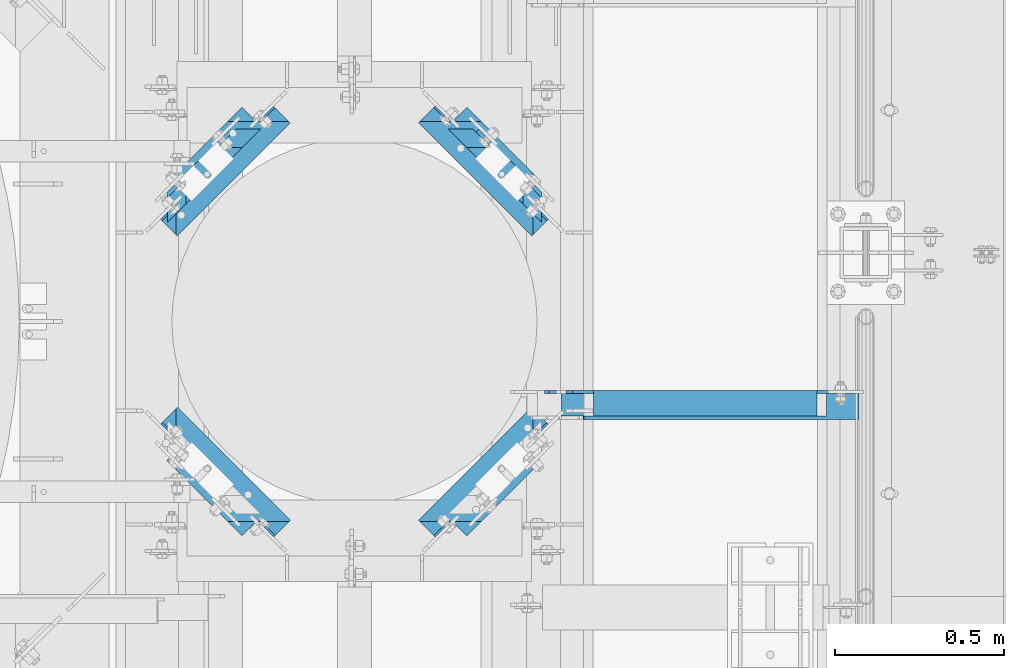
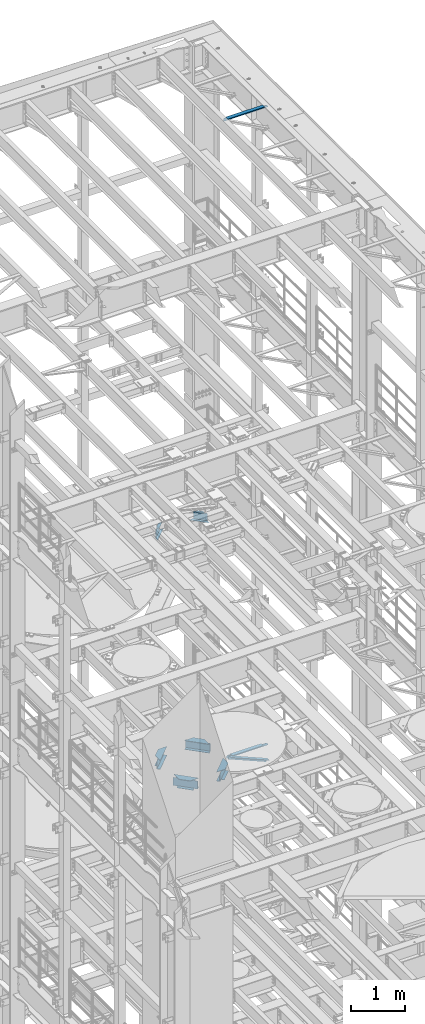
# One storey, part 1324 of 1876: 8 beams, 1 member, 9 elements without a shape of their own.
"""IFC2X3 building model written with IfcOpenShell, lengths in millimetres."""

import ifcopenshell
import ifcopenshell.guid

model = None  # the IFC model being written
_history = None  # IfcOwnerHistory: only IFC2X3 demands one
_inside = {}  # id of a spatial element -> (the spatial element, [elements in it])
_under = {}  # id of a project, library or spatial element -> (it, [spatial elements below it])
_declared = {}  # id of a project -> (the project, [libraries it declares])
_typed = {}  # id of a type object -> (the type object, [elements of that type])
_made_of = {}  # id of a material, layer set ... -> (it, [elements and type objects made of it])


def new_model(schema):
    """Start an empty IFC model of exactly this schema.

    Asked for "IFC4X3", IfcOpenShell would pick the latest addendum, in which some entities
    have other attributes; the version numbers below select the first issue.
    IFC2X3 requires an IfcOwnerHistory on every rooted entity: one is made here for all.
    """
    global model, _history
    if schema == "IFC4X3":
        model = ifcopenshell.file(schema_version=(4, 3, 0, 0))
    else:
        model = ifcopenshell.file(schema=schema)
    _inside.clear()
    _under.clear()
    _declared.clear()
    _typed.clear()
    _made_of.clear()
    _history = None
    if model.schema == "IFC2X3":
        org = make("IfcOrganization", Name="unknown")
        user = make(
            "IfcPersonAndOrganization",
            ThePerson=make("IfcPerson", FamilyName="unknown"),
            TheOrganization=org,
        )
        app = make(
            "IfcApplication",
            ApplicationDeveloper=org,
            Version="unknown",
            ApplicationFullName="unknown",
            ApplicationIdentifier="unknown",
        )
        _history = make(
            "IfcOwnerHistory",
            OwningUser=user,
            OwningApplication=app,
            ChangeAction="ADDED",
            CreationDate=0,
        )
    return model


def make(cls, **values):
    """One entity of the class cls with the attributes given. An attribute that is None is left unset."""
    return model.create_entity(
        cls, **{name: value for name, value in values.items() if value is not None}
    )


def rooted(cls, **values):
    """An entity with a GlobalId (a new one), such as an element, a storey or a relation."""
    return make(cls, GlobalId=ifcopenshell.guid.new(), OwnerHistory=_history, **values)


def si_unit(unit_type, name, prefix=None):
    """IfcSIUnit, for example si_unit("LENGTHUNIT", "METRE", prefix="MILLI")."""
    return make("IfcSIUnit", UnitType=unit_type, Prefix=prefix, Name=name)


def assignment(units):
    """IfcUnitAssignment: the units of a project."""
    return None if units is None else make("IfcUnitAssignment", Units=units)


def point(xyz):
    """IfcCartesianPoint."""
    return None if xyz is None else make("IfcCartesianPoint", Coordinates=xyz)


def direction(xyz):
    """IfcDirection."""
    return None if xyz is None else make("IfcDirection", DirectionRatios=xyz)


def frame(location, z_axis=None, x_axis=None):
    """IfcAxis2Placement3D, a coordinate frame: its origin and axes. An axis left out is left unset."""
    return make(
        "IfcAxis2Placement3D",
        Location=point(location),
        Axis=direction(z_axis),
        RefDirection=direction(x_axis),
    )


def origin_with_axes():
    """The frame at (0, 0, 0) with the z axis (0, 0, 1) and the x axis (1, 0, 0) written out."""
    return frame((0.0, 0.0, 0.0), z_axis=(0.0, 0.0, 1.0), x_axis=(1.0, 0.0, 0.0))


def place(relative_to, where):
    """IfcLocalPlacement: puts the frame where relative to a parent placement (None: the world)."""
    return make(
        "IfcLocalPlacement", PlacementRelTo=relative_to, RelativePlacement=where
    )


def context(
    kind, dimensions, precision=None, world=None, true_north=None, identifier=None
):
    """IfcGeometricRepresentationContext, for example the 3D "Model" context."""
    return make(
        "IfcGeometricRepresentationContext",
        ContextIdentifier=identifier,
        ContextType=kind,
        CoordinateSpaceDimension=dimensions,
        Precision=precision,
        WorldCoordinateSystem=world,
        TrueNorth=true_north,
    )


def subcontext(parent, identifier, kind, view, scale=None):
    """IfcGeometricRepresentationSubContext, for example "Body" below "Model"."""
    return make(
        "IfcGeometricRepresentationSubContext",
        ContextIdentifier=identifier,
        ContextType=kind,
        ParentContext=parent,
        TargetScale=scale,
        TargetView=view,
    )


def project(units=None, contexts=None):
    """IfcProject with its units and contexts."""
    return rooted(
        "IfcProject",
        Name="project",
        RepresentationContexts=contexts,
        UnitsInContext=assignment(units),
    )


def spatial(cls, under=None, at=None, **own):
    """A site, building, storey or space (cls), placed at a placement, below another one or the project."""
    s = rooted(cls, ObjectPlacement=at, **own)
    if under is not None:
        _under.setdefault(under.id(), (under, []))[1].append(s)
    return s


def faces_of(points, faces, orient=None, outer=None):
    """IfcFace entities. A face is a list of loops; a loop is a list of indices into points, from 0.

    orient and outer hold one flag for each loop. By default every Orientation is true, the
    first loop of a face is its IfcFaceOuterBound and the others are IfcFaceBound.
    """
    made = []
    for i, loops in enumerate(faces):
        bounds = []
        for j, loop in enumerate(loops):
            is_outer = j == 0 if outer is None else outer[i][j]
            bounds.append(
                make(
                    "IfcFaceOuterBound" if is_outer else "IfcFaceBound",
                    Bound=make("IfcPolyLoop", Polygon=[points[k] for k in loop]),
                    Orientation=True if orient is None else orient[i][j],
                )
            )
        made.append(make("IfcFace", Bounds=bounds))
    return made


def faceted_brep(points, faces, orient=None, outer=None, voids=None):
    """IfcFacetedBrep: a solid bounded by flat faces; with voids (closed shells), ...WithVoids."""
    shared = [point(p) for p in points]
    hull = make("IfcClosedShell", CfsFaces=faces_of(shared, faces, orient, outer))
    if voids is None:
        return make("IfcFacetedBrep", Outer=hull)
    return make(
        "IfcFacetedBrepWithVoids",
        Outer=hull,
        Voids=[
            make(cls, CfsFaces=faces_of(shared, fs, o, b)) for cls, fs, o, b in voids
        ],
    )


def shape(context_of_items, identifier, shape_type, items):
    """IfcShapeRepresentation: the items that make up one representation, for example the "Body"."""
    return make(
        "IfcShapeRepresentation",
        ContextOfItems=context_of_items,
        RepresentationIdentifier=identifier,
        RepresentationType=shape_type,
        Items=items,
    )


def material(Name=None, Category=None):
    """IfcMaterial."""
    return make("IfcMaterial", Name=Name, Category=Category)


def made_of(thing, what):
    """Note that an element or type object is made of a material, layer set ...; save() writes the relation."""
    if what is not None:
        _made_of.setdefault(what.id(), (what, []))[1].append(thing)
    return thing


def type_object(cls, material=None, **own):
    """A type object (cls), such as IfcWallType, which elements share."""
    return made_of(rooted(cls, **own), material)


def element(
    cls,
    number,
    at=None,
    inside=None,
    cuts=None,
    type_object=None,
    material=None,
    context=None,
    identifier="Body",
    shape_type=None,
    held_by="IfcProductDefinitionShape",
    body=None,
    shapes=None,
    **own,
):
    """One element of the class cls, such as IfcWall. Its Tag is "e" and its number.

    at: its placement. inside: the storey or other place that contains it. cuts: it is an
    opening in that element (IfcRelVoidsElement). A single representation is given by context,
    identifier, shape_type and body (its items); several are given by shapes. held_by: the class
    of the entity that holds the representations. save() writes the other relations.
    """
    e = rooted(cls, Tag="e%d" % number, ObjectPlacement=at, **own)
    if body is not None:
        shapes = [shape(context, identifier, shape_type, body)]
    if shapes is not None:
        e.Representation = make(held_by, Representations=shapes)
    if inside is not None:
        _inside.setdefault(inside.id(), (inside, []))[1].append(e)
    if cuts is not None:
        rooted(
            "IfcRelVoidsElement", RelatingBuildingElement=cuts, RelatedOpeningElement=e
        )
    if type_object is not None:
        _typed.setdefault(type_object.id(), (type_object, []))[1].append(e)
    return made_of(e, material)


def aggregate(whole, parts):
    """IfcRelAggregates: a whole, such as a stair, and the parts it consists of."""
    return rooted("IfcRelAggregates", RelatingObject=whole, RelatedObjects=parts)


def save(model, path):
    """Write the relations noted so far, then the file.

    IfcRelAggregates (storeys below a building ...), IfcRelContainedInSpatialStructure (elements
    in a storey), IfcRelDefinesByType, IfcRelAssociatesMaterial and IfcRelDeclares: one each for
    every whole, place, type object, material and project.
    """
    for whole, parts in _under.values():
        aggregate(whole, parts)
    for where, things in _inside.values():
        rooted(
            "IfcRelContainedInSpatialStructure",
            RelatedElements=things,
            RelatingStructure=where,
        )
    for kind, things in _typed.values():
        rooted("IfcRelDefinesByType", RelatedObjects=things, RelatingType=kind)
    for what, things in _made_of.values():
        rooted("IfcRelAssociatesMaterial", RelatedObjects=things, RelatingMaterial=what)
    for by, libraries in _declared.values():
        rooted("IfcRelDeclares", RelatingContext=by, RelatedDefinitions=libraries)
    model.write(path)


model = new_model("IFC2X3")

# Units and contexts
model_context = context("Model", 3, precision=1e-05, world=origin_with_axes())
body_context = subcontext(model_context, "Body", "Model", "MODEL_VIEW")
ifc_project = project(units=[si_unit("LENGTHUNIT", "METRE", prefix="MILLI"), si_unit("AREAUNIT", "SQUARE_METRE"), si_unit("VOLUMEUNIT", "CUBIC_METRE"), si_unit("MASSUNIT", "GRAM", prefix="KILO"), si_unit("TIMEUNIT", "SECOND"), si_unit("PLANEANGLEUNIT", "RADIAN"), si_unit("SOLIDANGLEUNIT", "STERADIAN"), si_unit("THERMODYNAMICTEMPERATUREUNIT", "DEGREE_CELSIUS"), si_unit("LUMINOUSINTENSITYUNIT", "LUMEN")], contexts=[model_context])

# Site, building, storey
site_placement = place(None, origin_with_axes())
site = spatial("IfcSite", under=ifc_project, at=site_placement, CompositionType="ELEMENT")
building_placement = place(site_placement, origin_with_axes())
building = spatial("IfcBuilding", under=site, at=building_placement, Name="Undefined", CompositionType="ELEMENT")
storey_placement = place(building_placement, origin_with_axes())
storey = spatial("IfcBuildingStorey", under=building, at=storey_placement, Name="Undefined", CompositionType="ELEMENT", Elevation=0.0)

# Assembly, member
assembly_1_placement = place(storey_placement, origin_with_axes())
assembly_1 = element("IfcElementAssembly", 1, at=assembly_1_placement, inside=storey, AssemblyPlace="NOTDEFINED", PredefinedType="RIGID_FRAME")
ifc_material = material(Name="STEEL/A36")
member_type = type_object("IfcMemberType", Name="L3X3X3/8", PredefinedType="NOTDEFINED")
member_placement = place(assembly_1_placement, frame((6716.15062848994, 11229.975, 8118.31287749607), z_axis=(0.0, -1.0, 0.0), x_axis=(0.920921850882514, 0.0, -0.389747282950278)))
member = element("IfcMember", 2, at=member_placement, type_object=member_type, material=ifc_material, ObjectType="L3X3X3/8", context=body_context, shape_type="Brep", body=[
    faceted_brep([(61.0981387968259, 38.0999999999804, -38.1000000000004), (61.0981387968259, 38.0999999999804, 38.1000000000004), (943.789366270678, 38.0999999998294, 38.1000000000004), (943.789366270678, 38.0999999998294, -38.1000000000004), (61.0981387968254, 28.5749999999825, 38.1000000000004), (943.789366270677, 28.5749999998316, 38.1000000000004), (61.0981387968254, 28.5749999999825, -28.5750000000007), (943.789366270677, 28.5749999998316, -28.5750000000007), (61.0981387968263, -38.1000000000022, -28.5750000000007), (943.789366270679, -38.1000000001513, -28.5750000000007), (61.0981387968263, -38.1000000000022, -38.1000000000004), (943.789366270679, -38.1000000001513, -38.1000000000004)], [[[0, 1, 2, 3]], [[1, 4, 5, 2]], [[4, 6, 7, 5]], [[6, 8, 9, 7]], [[8, 10, 11, 9]], [[10, 0, 3, 11]], [[5, 7, 9, 11, 3, 2]], [[10, 8, 6, 4, 1, 0]]]),
])
aggregate(assembly_1, [member])

# Assembly, beam
assembly_2_placement = place(storey_placement, origin_with_axes())
assembly_2 = element("IfcElementAssembly", 3, at=assembly_2_placement, inside=storey, Name="ANGLE", AssemblyPlace="NOTDEFINED", PredefinedType="RIGID_FRAME")
beam_type_1 = type_object("IfcBeamType", Name="L3X3X3/8", PredefinedType="NOTDEFINED")
beam_1_placement = place(assembly_2_placement, frame((6667.50000000001, 11239.5, 22517.1000001129), z_axis=(0.0, -1.0, 0.0), x_axis=(1.0, 0.0, 0.0)))
beam_1 = element("IfcBeam", 4, at=beam_1_placement, type_object=beam_type_1, material=ifc_material, Name="ANGLE", ObjectType="L3X3X3/8", context=body_context, shape_type="Brep", body=[
    faceted_brep([(836.613000301995, 28.5750000000007, -28.5749999999998), (836.613001168791, 28.5750000000007, 38.0999999999999), (52.3870335430847, 28.5750001907327, 38.0999999999858), (52.3869956588824, 28.5749999999955, -28.5750000000007), (836.613001168791, 38.0999999999985, 38.0999999999999), (52.387033543122, 38.0999999999985, 38.0999999999858), (15.8749936676099, 28.5749999999989, -28.5750000000007), (15.8749999382144, 28.5750001907327, -38.0999999999999), (3.17500012894925, 15.8750003814675, -38.0999999999999), (3.17500032897624, 15.8750003814675, -28.5749999999998), (52.3870393343063, 28.5750001907327, -38.1000000000149), (52.3869953826566, 38.0999999999954, -38.0999999999985), (836.613000178167, 38.0999999999985, -38.0999999999999), (836.613000301995, 12.6999991241828, -28.5749999999998), (836.613000178167, 12.6999991241828, -38.0999999999999), (913.60625591723, 12.6999991241828, -28.5749999999998), (913.606255793401, 12.6999991241828, -38.0999999999999), (945.35625591723, -19.0500008758172, -28.5749999999998), (945.356255793401, -19.0500008758172, -38.0999999999999), (945.356249999983, -38.0999999999985, -28.5749999999998), (945.356249999983, -38.0999999999985, -38.0999999999999), (3.17499999075153, -38.0999999999985, -28.5749999999998), (3.17499999075153, -38.0999999999985, -38.0999999999999), (3.17500012894925, 3.17500152587672, -38.0999999999999), (3.17500032897624, 3.17500152587672, -28.5749999999998)], [[[0, 1, 2, 3]], [[1, 4, 5, 2]], [[6, 7, 8, 9]], [[3, 10, 7, 6]], [[2, 5, 11, 10, 3]], [[4, 12, 11, 5]], [[1, 0, 13, 14, 12, 4]], [[15, 16, 14, 13]], [[16, 15, 17, 18]], [[18, 17, 19, 20]], [[20, 19, 21, 22]], [[8, 7, 10, 11, 12, 14, 16, 18, 20, 22, 23]], [[9, 8, 23, 24]], [[19, 17, 15, 13, 0, 3, 6, 9, 24, 21]], [[23, 22, 21, 24]]]),
])
aggregate(assembly_2, [beam_1])

assembly_3_placement = place(storey_placement, origin_with_axes())
assembly_3 = element("IfcElementAssembly", 5, at=assembly_3_placement, inside=storey, Name="ANGLE", AssemblyPlace="NOTDEFINED", PredefinedType="RIGID_FRAME")
beam_2_placement = place(assembly_3_placement, frame((6730.99999999938, 11239.5, 8115.3), z_axis=(0.0, -1.0, 0.0), x_axis=(1.0, 0.0, 0.0)))
beam_2 = element("IfcBeam", 6, at=beam_2_placement, type_object=beam_type_1, material=ifc_material, Name="ANGLE", ObjectType="L3X3X3/8", context=body_context, shape_type="Brep", body=[
    faceted_brep([(744.538000225918, 28.5749999999998, -28.5750000000007), (744.538000959305, 28.5749999999998, 38.1000000000004), (84.1370686928021, 28.5750001907327, 38.100000000024), (84.1370606917826, 28.5750000000007, -28.5749999999771), (744.538000959288, 38.1000000000004, 38.1000000000004), (84.1374011325761, 38.0999999999985, 38.0999999999776), (22.2249552881549, 26.9870083863452, -28.5749999999935), (22.2249551643299, 26.9870094055232, -38.0999999999931), (3.17495592726937, 7.93701016846171, -38.0999999999995), (3.17495605109434, 7.93700914928468, -28.5749999999989), (84.1369575769495, 26.9870083863452, -28.5749999999744), (84.1369574531245, 26.9870094055223, -38.099999999974), (84.137408980816, 38.0999999999985, -38.1000000000231), (744.538000121132, 38.1000000000004, -38.1000000000004), (744.538000225876, 14.2869991302496, -28.5750000000007), (744.538000121098, 14.2869991302496, -38.1000000000004), (856.456253170776, 14.2869991302496, -28.5750000000007), (856.456253065998, 14.2869991302496, -38.1000000000004), (881.856252789306, -11.1130004882807, -28.5750000000007), (881.856252684528, -11.1130004882807, -38.1000000000004), (881.856250000624, -38.1000000000004, -28.5750000000007), (881.856250000624, -38.1000000000004, -38.1000000000004), (3.17499999075153, -38.0999999999985, -28.5749999999998), (3.17499999075153, -38.0999999999985, -38.0999999999999), (3.17495592726937, 1.58700978699198, -38.0999999999995), (3.17495605109434, 1.58700876781495, -28.5749999999989)], [[[0, 1, 2, 3]], [[1, 4, 5, 2]], [[6, 7, 8, 9]], [[10, 11, 7, 6]], [[2, 5, 12, 11, 10, 3]], [[4, 13, 12, 5]], [[1, 0, 14, 15, 13, 4]], [[16, 17, 15, 14]], [[17, 16, 18, 19]], [[19, 18, 20, 21]], [[21, 20, 22, 23]], [[8, 7, 11, 12, 13, 15, 17, 19, 21, 23, 24]], [[9, 8, 24, 25]], [[20, 18, 16, 14, 0, 3, 10, 6, 9, 25, 22]], [[24, 23, 22, 25]]]),
])
aggregate(assembly_3, [beam_2])

assembly_4_placement = place(storey_placement, origin_with_axes())
assembly_4 = element("IfcElementAssembly", 7, at=assembly_4_placement, inside=storey, Name="BEAM", AssemblyPlace="NOTDEFINED", PredefinedType="RIGID_FRAME")
beam_type_2 = type_object("IfcBeamType", Name="W8X18", PredefinedType="NOTDEFINED")
beam_3_placement = place(assembly_4_placement, frame((6312.94781657434, 10814.0704555271, 8050.2125), z_axis=(0.0, 0.0, -1.0), x_axis=(0.707277383601011, 0.706936137601204, 0.0)))
beam_3 = element("IfcBeam", 8, at=beam_3_placement, type_object=beam_type_2, material=ifc_material, Name="BEAM", ObjectType="W8X18", context=body_context, shape_type="Brep", body=[
    faceted_brep([(518.287382340195, 3.17406305276609, 103.1875), (518.287382340197, 3.17499999975962, 95.25), (510.391708907931, 3.17499999976326, 95.25), (510.391708907931, 3.17283308766901, 103.1875), (45.7826824666718, -66.6750000000279, -95.25), (45.7826824666718, -66.6750000000279, -103.1875), (518.287382340195, -66.6750000002453, -103.1875), (518.287382340195, -66.6750000002453, -95.25), (45.7826824666718, -61.94756078215, -95.25), (45.7826824666718, -61.94756078215, -103.1875), (450.026710267348, 3.14355010609188, 103.1875), (450.026695266628, 3.17499999979054, 95.25), (421.094188286748, 3.17499999980419, 95.25), (421.09418828675, 3.12951497766926, 103.1875), (45.7826824666718, -66.6750000000279, 95.25), (45.7826824666718, -3.17500000002246, 95.25), (518.287382340195, -3.17500000024165, 95.25), (518.287382340195, -66.6750000002453, 95.25), (45.7826824666718, -66.6750000000279, 103.1875), (518.287382340195, -66.6750000002453, 103.1875), (421.165702739307, 66.6749999998106, 103.1875), (114.007783163774, 66.6749999999515, 103.1875), (114.007312602282, 3.17553032649312, 103.1875), (45.7826824666718, 3.1760359037321, 103.1875), (421.165702739307, 66.6749999998106, 95.25), (114.007783171714, 66.6749999999524, 95.25), (114.007312602349, 3.17499999994607, 95.25), (45.7826824666718, 3.17499999997881, 95.25), (45.7826824666718, 3.17499999997881, 77.7959944558679), (45.7826824666718, 3.17499999997881, 75.3524994325744), (45.7826824666718, 3.17499999997881, -77.7875000000004), (45.7826824666718, -3.17500000002246, -77.7875000000004), (92.971831273373, 3.17499999995607, -77.7875000000004), (86.6187660571795, -3.17500000004247, -77.7875000000004), (99.8466807251734, 3.17499999995243, -78.7542299225879), (93.4936155089799, -3.17500000004429, -78.7542299225879), (105.674896668601, 3.17499999995061, -81.5072438230663), (99.3218314524056, -3.17500000004702, -81.5072438230663), (109.569186059178, 3.1749999999497, -85.62742029122), (103.216120842984, -3.17500000004793, -85.62742029122), (110.936678639015, 3.17499999994698, -90.4874998092655), (104.583613422821, -3.17500000005066, -90.4874998092655), (174.467330800953, 66.6749999999233, -95.25), (174.467330800953, 66.6749999999233, -103.1875), (104.583613422821, -3.17500000005066, -95.25), (110.936678639015, 3.17499999994698, -95.25), (453.227646851157, 3.17499999978963, -95.25), (389.758284224083, 66.6749999998242, -95.25), (389.758284224083, 66.6749999998242, -103.1875), (518.287382340195, -61.9161405530208, -103.1875), (518.287382340195, -61.9161405530208, -95.25), (459.574583113865, -3.17500000021346, -95.25), (459.574583113865, -3.17500000021437, -90.4874998092655), (460.941415908188, -3.17500000021437, -85.62742029122), (464.833826388591, -3.17500000021619, -81.5072438230663), (470.659230344218, -3.17500000021892, -78.7542299225879), (477.530762830249, -3.17500000022164, -77.7875000000004), (518.287382340195, -3.17500000024165, -77.7875000000004), (453.227646851157, 3.17499999978872, -90.4874998092655), (454.594479645481, 3.17499999978963, -85.62742029122), (458.486890125883, 3.17499999978691, -81.5072438230663), (464.31229408151, 3.17499999978509, -78.7542299225879), (471.183826567541, 3.17499999978145, -77.7875000000004), (518.287382340197, 3.17499999975962, -77.7875000000004), (518.287382340197, 3.17499999975962, 77.7968439093429), (518.287382340197, 3.17499999975962, 75.3525023057064)], [[[0, 1, 2, 3]], [[4, 5, 6, 7]], [[5, 4, 8, 9]], [[10, 3, 2, 11, 12, 13]], [[14, 15, 16, 17]], [[18, 14, 17, 19]], [[10, 13, 20, 21, 22, 23, 18, 19, 0, 3]], [[20, 24, 25, 21]], [[13, 12, 24, 20]], [[24, 12, 26, 25]], [[21, 25, 26, 22]], [[22, 26, 27, 23]], [[28, 29, 30, 31, 15, 14, 18, 23, 27]], [[32, 33, 31, 30]], [[34, 35, 33, 32]], [[36, 37, 35, 34]], [[38, 39, 37, 36]], [[40, 41, 39, 38]], [[42, 43, 9, 8, 44, 41, 40, 45]], [[42, 45, 46, 47]], [[43, 42, 47, 48]], [[6, 5, 9, 43, 48, 49]], [[7, 6, 49, 50]], [[44, 8, 4, 7, 50, 51]], [[16, 15, 31, 33, 35, 37, 39, 41, 44, 51, 52, 53, 54, 55, 56, 57]], [[50, 49, 48, 47, 46, 58, 52, 51]], [[52, 58, 59, 53]], [[53, 59, 60, 54]], [[54, 60, 61, 55]], [[55, 61, 62, 56]], [[57, 56, 62, 63]], [[61, 60, 59, 58, 46, 45, 40, 38, 36, 34, 32, 30, 29, 28, 27, 26, 12, 11, 2, 1, 64, 65, 63, 62]], [[19, 17, 16, 57, 63, 65, 64, 1, 0]]]),
])
aggregate(assembly_4, [beam_3])

assembly_5_placement = place(storey_placement, origin_with_axes())
assembly_5 = element("IfcElementAssembly", 9, at=assembly_5_placement, inside=storey, Name="BEAM", AssemblyPlace="NOTDEFINED", PredefinedType="RIGID_FRAME")
beam_4_placement = place(assembly_5_placement, frame((5904.45218342566, 10814.0704555271, 8050.2125), z_axis=(0.0, 0.0, -1.0), x_axis=(-0.707277383601011, 0.706936137601204, 0.0)))
beam_4 = element("IfcBeam", 10, at=beam_4_placement, type_object=beam_type_2, material=ifc_material, Name="BEAM", ObjectType="W8X18", context=body_context, shape_type="Brep", body=[
    faceted_brep([(518.287382340192, 61.9161405536761, -95.25), (459.574583113207, 3.17500000021391, -95.25), (459.574583113207, 3.17500000021391, -90.4874998092655), (453.2276468505, -3.17499999978827, -90.4874998092655), (453.2276468505, -3.17499999978827, -95.25), (389.758284223425, -66.6749999998246, -95.25), (389.758284223425, -66.6749999998246, -103.1875), (518.287382340192, 61.9161405536761, -103.1875), (460.941415907529, 3.17500000021391, -85.62742029122), (454.594479644821, -3.17499999978827, -85.62742029122), (464.833826387931, 3.17500000021755, -81.5072438230663), (458.486890125224, -3.17499999978645, -81.5072438230663), (470.65923034356, 3.17500000021937, -78.7542299225879), (464.312294080854, -3.17499999978281, -78.7542299225879), (477.53076282959, 3.17500000022119, -77.7875000000004), (471.183826566882, -3.17499999978099, -77.7875000000004), (518.287382340195, -3.17500000024165, -77.7875000000004), (518.287382340197, 3.17499999975962, -77.7875000000004), (429.061376196296, -66.6749999998046, 95.25), (429.061376196296, -66.6749999998046, 103.1875), (114.006792095311, -66.674999999952, 103.1875), (114.006792103251, -66.674999999952, 95.25), (428.989861743737, -3.13168204770409, 103.1875), (518.287382364922, -3.17500015770202, 103.1875), (518.287382340191, 66.6750000002467, 103.1875), (45.7826824666713, 66.6750000000284, 103.1875), (45.7826824666713, -3.1739641377244, 103.1875), (114.007262619808, -3.17446966644275, 103.1875), (45.7826824666713, 66.6750000000284, 95.25), (518.287382340191, 66.6750000002467, 95.25), (45.7826824666718, 3.17499999997881, 95.25), (518.287382340197, 3.17499999975962, 95.25), (45.7826824666713, 66.6750000000284, -103.1875), (45.7826824666713, 66.6750000000284, -95.25), (518.287382340191, 66.6750000002467, -95.25), (518.287382340191, 66.6750000002467, -103.1875), (45.7826824666722, 61.9475607818331, -103.1875), (45.7826824666722, 61.9475607818331, -95.25), (174.467330800636, -66.6749999999229, -95.25), (110.936678638697, -3.17499999994652, -95.25), (110.936678638697, -3.17499999994652, -90.4874998092655), (104.583613422503, 3.1750000000502, -90.4874998092655), (104.583613422503, 3.1750000000502, -95.25), (174.467330800636, -66.6749999999229, -103.1875), (109.56918605886, -3.17499999994834, -85.62742029122), (103.216120842666, 3.1750000000502, -85.62742029122), (105.674896668281, -3.17499999995016, -81.5072438230663), (99.3218314520877, 3.17500000004657, -81.5072438230663), (99.8466807248537, -3.17499999995198, -78.7542299225879), (93.4936155086602, 3.17500000004475, -78.7542299225879), (92.9718312730561, -3.17499999995562, -77.7875000000004), (86.6187660568617, 3.17500000004293, -77.7875000000004), (45.7826824666718, -3.17500000002246, -77.7875000000004), (45.7826824666718, 3.17499999997881, -77.7875000000004), (45.7826824666722, -3.17499999997744, 75.3524977472252), (45.7826824666722, -3.17499999997744, 77.7968438683665), (45.7826824666718, -3.17500000002246, 95.25), (114.007262619881, -3.17499999994652, 95.25), (428.989861743737, -3.174999999801, 95.25), (518.287382340195, -3.17500000024165, 95.25), (518.287382340192, -3.17499999975917, 75.3525023057064), (518.287382340192, -3.17499999975917, 71.7994964599593)], [[[0, 1, 2, 3, 4, 5, 6, 7]], [[8, 9, 3, 2]], [[10, 11, 9, 8]], [[12, 13, 11, 10]], [[14, 15, 13, 12]], [[16, 15, 14, 17]], [[18, 19, 20, 21]], [[19, 22, 23, 24, 25, 26, 27, 20]], [[28, 25, 24, 29]], [[30, 28, 29, 31]], [[32, 33, 34, 35]], [[33, 32, 36, 37]], [[38, 39, 40, 41, 42, 37, 36, 43]], [[44, 45, 41, 40]], [[46, 47, 45, 44]], [[48, 49, 47, 46]], [[50, 51, 49, 48]], [[52, 53, 51, 50]], [[25, 28, 30, 53, 52, 54, 55, 56, 26]], [[26, 56, 57, 27]], [[20, 27, 57, 21]], [[58, 18, 21, 57]], [[19, 18, 58, 22]], [[23, 22, 58, 59]], [[31, 29, 24, 23, 59, 60, 61, 16, 17]], [[12, 10, 8, 2, 1, 42, 41, 45, 47, 49, 51, 53, 30, 31, 17, 14]], [[34, 33, 37, 42, 1, 0]], [[35, 34, 0, 7]], [[43, 36, 32, 35, 7, 6]], [[38, 43, 6, 5]], [[39, 38, 5, 4]], [[61, 60, 59, 58, 57, 56, 55, 54, 52, 50, 48, 46, 44, 40, 39, 4, 3, 9, 11, 13, 15, 16]]]),
])
aggregate(assembly_5, [beam_4])

assembly_6_placement = place(storey_placement, origin_with_axes())
assembly_6 = element("IfcElementAssembly", 11, at=assembly_6_placement, inside=storey, Name="BEAM", AssemblyPlace="NOTDEFINED", PredefinedType="RIGID_FRAME")
beam_5_placement = place(assembly_6_placement, frame((6312.94781657434, 12147.5295444729, 8050.2125), z_axis=(0.0, 0.0, -1.0), x_axis=(0.707277383601011, -0.706936137601204, 0.0)))
beam_5 = element("IfcBeam", 12, at=beam_5_placement, type_object=beam_type_2, material=ifc_material, Name="BEAM", ObjectType="W8X18", context=body_context, shape_type="Brep", body=[
    faceted_brep([(518.287382340194, -3.17593707890228, 103.1875), (510.391708910342, -3.16121359744466, 103.1875), (510.391708910341, -3.17499999976826, 95.25), (518.287382340195, -3.17500000024165, 95.25), (45.7826824666718, 3.17499999997881, 95.25), (45.7826824666713, 66.6750000000284, 95.25), (518.287382340191, 66.6750000002467, 95.25), (518.287382340197, 3.17499999975962, 95.25), (518.287382340191, 66.6750000002467, -103.1875), (518.287382340191, 66.6750000002467, -95.25), (518.287382340192, 61.9161405536761, -95.25), (518.287382340192, 61.9161405536761, -103.1875), (45.7826824666713, 66.6750000000284, -103.1875), (45.7826824666713, 66.6750000000284, -95.25), (45.7826824666722, 61.9475607818331, -103.1875), (45.7826824666722, 61.9475607818331, -95.25), (104.583613422503, 3.1750000000502, -95.25), (459.574583113207, 3.17500000021391, -95.25), (477.53076282959, 3.17500000022119, -77.7875000000004), (471.183826566882, -3.17499999978099, -77.7875000000004), (464.312294080854, -3.17499999978281, -78.7542299225879), (470.65923034356, 3.17500000021937, -78.7542299225879), (458.486890125224, -3.17499999978645, -81.5072438230663), (464.833826387931, 3.17500000021755, -81.5072438230663), (454.594479644821, -3.17499999978827, -85.62742029122), (460.941415907529, 3.17500000021391, -85.62742029122), (453.2276468505, -3.17499999978827, -90.4874998092655), (459.574583113207, 3.17500000021391, -90.4874998092655), (110.936678638697, -3.17499999994652, -95.25), (174.467330800636, -66.6749999999229, -95.25), (389.758284223425, -66.6749999998246, -95.25), (453.2276468505, -3.17499999978827, -95.25), (174.467330800636, -66.6749999999229, -103.1875), (389.758284223425, -66.6749999998246, -103.1875), (110.936678638697, -3.17499999994652, -90.4874998092655), (104.583613422503, 3.1750000000502, -90.4874998092655), (109.56918605886, -3.17499999994834, -85.62742029122), (103.216120842666, 3.1750000000502, -85.62742029122), (105.674896668281, -3.17499999995016, -81.5072438230663), (99.3218314520877, 3.17500000004657, -81.5072438230663), (99.8466807248537, -3.17499999995198, -78.7542299225879), (93.4936155086602, 3.17500000004475, -78.7542299225879), (92.9718312730561, -3.17499999995562, -77.7875000000004), (86.6187660568617, 3.17500000004293, -77.7875000000004), (45.7826824666718, -3.17500000002246, -77.7875000000004), (45.7826824666718, 3.17499999997881, -77.7875000000004), (421.165702741715, -66.6749999998119, 103.1875), (421.165702741715, -66.6749999998119, 95.25), (421.094188289158, -3.17499999980828, 95.25), (421.094188289158, -3.11789548744309, 103.1875), (114.006792095311, -66.674999999952, 103.1875), (114.006792103251, -66.674999999952, 95.25), (114.007262619881, -3.17499999994652, 95.25), (114.007262619808, -3.17446966644275, 103.1875), (45.7826824666713, -3.1739641377244, 103.1875), (45.7826824666718, -3.17500000002246, 95.25), (45.7826824666713, 66.6750000000284, 103.1875), (45.7826824666722, -3.17499999997744, 75.3524977472252), (45.7826824666722, -3.17499999997744, 77.7968438683665), (518.287382340191, 66.6750000002467, 103.1875), (518.287382340193, -3.17499999976462, 77.795994455887), (518.287382340192, -3.17499999975917, 75.3525023057064), (518.287382340195, -3.17500000024165, -77.7875000000004), (518.287382340197, 3.17499999975962, -77.7875000000004), (450.026654501595, -3.17499999979373, 95.25), (450.026675653376, -3.13193059907462, 103.1875)], [[[0, 1, 2, 3]], [[4, 5, 6, 7]], [[8, 9, 10, 11]], [[12, 13, 9, 8]], [[13, 12, 14, 15]], [[9, 13, 15, 16, 17, 10]], [[18, 19, 20, 21]], [[21, 20, 22, 23]], [[23, 22, 24, 25]], [[25, 24, 26, 27]], [[28, 29, 30, 31]], [[29, 32, 33, 30]], [[10, 17, 27, 26, 31, 30, 33, 11]], [[32, 14, 12, 8, 11, 33]], [[29, 28, 34, 35, 16, 15, 14, 32]], [[36, 37, 35, 34]], [[38, 39, 37, 36]], [[40, 41, 39, 38]], [[42, 43, 41, 40]], [[44, 45, 43, 42]], [[46, 47, 48, 49]], [[47, 46, 50, 51]], [[48, 47, 51, 52]], [[50, 53, 52, 51]], [[54, 55, 52, 53]], [[56, 5, 4, 45, 44, 57, 58, 55, 54]], [[5, 56, 59, 6]], [[60, 61, 62, 63, 7, 6, 59, 0, 3]], [[21, 23, 25, 27, 17, 16, 35, 37, 39, 41, 43, 45, 4, 7, 63, 18]], [[62, 19, 18, 63]], [[61, 60, 3, 2, 64, 48, 52, 55, 58, 57, 44, 42, 40, 38, 36, 34, 28, 31, 26, 24, 22, 20, 19, 62]], [[65, 49, 48, 64, 2, 1]], [[59, 56, 54, 53, 50, 46, 49, 65, 1, 0]]]),
])
aggregate(assembly_6, [beam_5])

assembly_7_placement = place(storey_placement, origin_with_axes())
assembly_7 = element("IfcElementAssembly", 13, at=assembly_7_placement, inside=storey, Name="BEAM", AssemblyPlace="NOTDEFINED", PredefinedType="RIGID_FRAME")
beam_6_placement = place(assembly_7_placement, frame((5904.45218342566, 12147.5295444729, 8050.2125), z_axis=(0.0, 0.0, -1.0), x_axis=(-0.707277383601011, -0.706936137601204, 0.0)))
beam_6 = element("IfcBeam", 14, at=beam_6_placement, type_object=beam_type_2, material=ifc_material, Name="BEAM", ObjectType="W8X18", context=body_context, shape_type="Brep", body=[
    faceted_brep([(518.287382340193, 3.17433310925753, 103.1875), (518.287382340197, 3.17499999975962, 95.25), (510.391708907931, 3.17499999976326, 95.25), (510.391708907931, 3.17283308766901, 103.1875), (45.7826824666718, -66.6750000000279, -95.25), (45.7826824666718, -66.6750000000279, -103.1875), (518.287382340195, -66.6750000002453, -103.1875), (518.287382340195, -66.6750000002453, -95.25), (45.7826824666718, -61.94756078215, -95.25), (45.7826824666718, -61.94756078215, -103.1875), (500.826573731298, 3.16819305315494, 103.1875), (500.826570686875, 3.17499999976735, 95.25), (421.094188286748, 3.17499999980419, 95.25), (421.09418828675, 3.12951497766926, 103.1875), (45.7826824666718, -66.6750000000279, 95.25), (45.7826824666718, -3.17500000002246, 95.25), (518.287382340195, -3.17500000024165, 95.25), (518.287382340195, -66.6750000002453, 95.25), (45.7826824666718, -66.6750000000279, 103.1875), (518.287382340195, -66.6750000002453, 103.1875), (421.165702739307, 66.6749999998106, 103.1875), (114.007783163774, 66.6749999999515, 103.1875), (114.007312602282, 3.17553032649312, 103.1875), (45.7826824666718, 3.1760359037321, 103.1875), (421.165702739307, 66.6749999998106, 95.25), (114.007783171714, 66.6749999999524, 95.25), (114.007312602349, 3.17499999994607, 95.25), (45.7826824666718, 3.17499999997881, 95.25), (45.7826824666718, 3.17499999997881, 77.7959944558679), (45.7826824666718, 3.17499999997881, 75.3524994325744), (45.7826824666718, 3.17499999997881, -77.7875000000004), (45.7826824666718, -3.17500000002246, -77.7875000000004), (92.971831273373, 3.17499999995607, -77.7875000000004), (86.6187660571795, -3.17500000004247, -77.7875000000004), (99.8466807251734, 3.17499999995243, -78.7542299225879), (93.4936155089799, -3.17500000004429, -78.7542299225879), (105.674896668601, 3.17499999995061, -81.5072438230663), (99.3218314524056, -3.17500000004702, -81.5072438230663), (109.569186059178, 3.1749999999497, -85.62742029122), (103.216120842984, -3.17500000004793, -85.62742029122), (110.936678639015, 3.17499999994698, -90.4874998092655), (104.583613422821, -3.17500000005066, -90.4874998092655), (174.467330800953, 66.6749999999233, -95.25), (174.467330800953, 66.6749999999233, -103.1875), (104.583613422821, -3.17500000005066, -95.25), (110.936678639015, 3.17499999994698, -95.25), (453.227646851157, 3.17499999978963, -95.25), (389.758284224083, 66.6749999998242, -95.25), (389.758284224083, 66.6749999998242, -103.1875), (518.287382340195, -61.9161405530208, -103.1875), (518.287382340195, -61.9161405530208, -95.25), (459.574583113865, -3.17500000021346, -95.25), (459.574583113865, -3.17500000021437, -90.4874998092655), (460.941415908188, -3.17500000021437, -85.62742029122), (464.833826388591, -3.17500000021619, -81.5072438230663), (470.659230344218, -3.17500000021892, -78.7542299225879), (477.530762830249, -3.17500000022164, -77.7875000000004), (518.287382340195, -3.17500000024165, -77.7875000000004), (453.227646851157, 3.17499999978872, -90.4874998092655), (454.594479645481, 3.17499999978963, -85.62742029122), (458.486890125883, 3.17499999978691, -81.5072438230663), (464.31229408151, 3.17499999978509, -78.7542299225879), (471.183826567541, 3.17499999978145, -77.7875000000004), (518.287382340197, 3.17499999975962, -77.7875000000004), (518.287382340197, 3.17499999975962, 77.7968439093429), (518.287382340197, 3.17499999975962, 75.3525023057064)], [[[0, 1, 2, 3]], [[4, 5, 6, 7]], [[5, 4, 8, 9]], [[10, 3, 2, 11, 12, 13]], [[14, 15, 16, 17]], [[18, 14, 17, 19]], [[10, 13, 20, 21, 22, 23, 18, 19, 0, 3]], [[20, 24, 25, 21]], [[13, 12, 24, 20]], [[24, 12, 26, 25]], [[21, 25, 26, 22]], [[22, 26, 27, 23]], [[28, 29, 30, 31, 15, 14, 18, 23, 27]], [[32, 33, 31, 30]], [[34, 35, 33, 32]], [[36, 37, 35, 34]], [[38, 39, 37, 36]], [[40, 41, 39, 38]], [[42, 43, 9, 8, 44, 41, 40, 45]], [[42, 45, 46, 47]], [[43, 42, 47, 48]], [[6, 5, 9, 43, 48, 49]], [[7, 6, 49, 50]], [[44, 8, 4, 7, 50, 51]], [[16, 15, 31, 33, 35, 37, 39, 41, 44, 51, 52, 53, 54, 55, 56, 57]], [[50, 49, 48, 47, 46, 58, 52, 51]], [[52, 58, 59, 53]], [[53, 59, 60, 54]], [[54, 60, 61, 55]], [[55, 61, 62, 56]], [[57, 56, 62, 63]], [[61, 60, 59, 58, 46, 45, 40, 38, 36, 34, 32, 30, 29, 28, 27, 26, 12, 11, 2, 1, 64, 65, 63, 62]], [[19, 17, 16, 57, 63, 65, 64, 1, 0]]]),
])
aggregate(assembly_7, [beam_6])

assembly_8_placement = place(storey_placement, origin_with_axes())
assembly_8 = element("IfcElementAssembly", 15, at=assembly_8_placement, inside=storey, Name="BEAM", AssemblyPlace="NOTDEFINED", PredefinedType="RIGID_FRAME")
beam_type_3 = type_object("IfcBeamType", Name="C8X18.75", PredefinedType="NOTDEFINED")
beam_7_placement = place(assembly_8_placement, frame((6645.04935969732, 11835.7921699833, 13208.0), z_axis=(0.0, 0.0, -1.0), x_axis=(-0.707106781186548, 0.707106781186547, 0.0)))
beam_7 = element("IfcBeam", 16, at=beam_7_placement, type_object=beam_type_3, material=ifc_material, Name="BEAM", ObjectType="C8X18.75", context=body_context, shape_type="Brep", body=[
    faceted_brep([(67.3519190196753, 31.7500000000055, -69.8500000000004), (54.6519190196727, 19.0500000000029, -69.8500000000004), (-3.71974387894079, 19.0500000000029, -69.8500000000004), (8.98025612106085, 31.7500000000055, -69.8500000000004), (74.2251093883087, 31.7500000000055, -70.8167299225879), (61.5251093883062, 19.0500000000029, -70.8167299225879), (80.0519188289445, 31.7500000000055, -73.5697438230654), (67.351918828942, 19.0500000000029, -73.5697438230654), (83.9452684244034, 31.7500000000055, -77.6899202912191), (71.2452684244008, 19.0500000000029, -77.6899202912191), (85.3124309920795, 31.7500000000055, -82.5499998092655), (72.612430992077, 19.0500000000029, -82.5499998092655), (85.3124309920795, 31.7500000000055, -101.6), (21.8124309920686, -31.7500000000055, -101.6), (21.8124309920686, -31.7500000000055, -97.3645500000002), (72.612430992077, 19.0500000000029, -88.9012700000003), (333.522984183766, -31.7500000000073, 101.6), (333.522984183766, -31.7500000000073, 97.3645500000002), (282.722984183757, 19.0500000000029, 88.9012700000003), (282.722983993118, 19.050000190744, 101.6), (-54.5197438789492, -31.7500000000055, 101.6), (-54.5197438789492, -31.7500000000055, 97.3645500000002), (-3.71974387894079, 19.0500000000029, 88.9012700000003), (270.022984183847, 19.0500000000029, 88.9012700000003), (257.190809313624, -31.7500000000055, -97.3645500000002), (257.190809313624, -31.7500000000055, -101.6), (193.690809313613, 31.7500000000055, -101.6), (193.690809313613, 31.7500000000055, -82.5499998092655), (206.390809313616, 19.0500000000029, -82.5499998092655), (206.390809313616, 19.0500000000029, -88.9012700000003), (195.057971881289, 31.7500000000055, -77.6899202912191), (207.757971881291, 19.0500000000029, -77.6899202912191), (198.951321476748, 31.7500000000055, -73.5697438230654), (211.65132147675, 19.0500000000029, -73.5697438230654), (204.778130917384, 31.7500000000055, -70.8167299225879), (217.478130917387, 19.0500000000029, -70.8167299225879), (211.651321286017, 31.7500000000036, -69.8500000000004), (224.351321286019, 19.0500000000029, -69.8500000000004), (270.022984183847, 19.0500000000029, -69.8500000000004), (270.022984183755, 31.7500000000036, -69.8500000000004), (270.022984183755, 31.7500000000036, 101.6), (270.022984183847, 19.050000190744, 101.6), (8.98025612106085, 31.7500000000055, 101.6)], [[[0, 1, 2, 3]], [[4, 5, 1, 0]], [[6, 7, 5, 4]], [[8, 9, 7, 6]], [[10, 11, 9, 8]], [[12, 13, 14, 15, 11, 10]], [[16, 17, 18, 19]], [[20, 21, 17, 16]], [[17, 21, 22, 23, 18]], [[24, 25, 26, 27, 28, 29]], [[28, 27, 30, 31]], [[31, 30, 32, 33]], [[33, 32, 34, 35]], [[35, 34, 36, 37]], [[38, 37, 36, 39]], [[40, 41, 23, 38, 39]], [[19, 18, 23, 41]], [[40, 42, 20, 16, 19, 41]], [[22, 21, 20, 42, 3, 2]], [[29, 28, 31, 33, 35, 37, 38, 23, 22, 2, 1, 5, 7, 9, 11, 15]], [[24, 29, 15, 14]], [[25, 24, 14, 13]], [[26, 25, 13, 12]], [[6, 4, 0, 3, 42, 40, 39, 36, 34, 32, 30, 27, 26, 12, 10, 8]]]),
])
aggregate(assembly_8, [beam_7])

assembly_9_placement = place(storey_placement, origin_with_axes())
assembly_9 = element("IfcElementAssembly", 17, at=assembly_9_placement, inside=storey, Name="BEAM", AssemblyPlace="NOTDEFINED", PredefinedType="RIGID_FRAME")
beam_8_placement = place(assembly_9_placement, frame((5831.51001530267, 12094.9515449833, 13208.0), z_axis=(0.0, 0.0, -1.0), x_axis=(-0.707106781186547, -0.707106781186548, 0.0)))
beam_8 = element("IfcBeam", 18, at=beam_8_placement, type_object=beam_type_3, material=ifc_material, Name="BEAM", ObjectType="C8X18.75", context=body_context, shape_type="Brep", body=[
    faceted_brep([(344.694271950037, -31.750000000005, -97.3645500000002), (344.694271950037, -31.750000000005, -101.6), (281.194271950028, 31.750000000005, -101.6), (281.194271950028, 31.750000000005, -82.5499998092655), (293.894271950028, 19.0500000000043, -82.5499998092655), (293.894271950028, 19.0500000000043, -88.9012700000003), (282.561434517702, 31.7500000000059, -77.6899202912191), (295.261434517704, 19.0500000000034, -77.6899202912191), (286.454784113161, 31.7500000000059, -73.5697438230654), (299.154784113163, 19.0500000000034, -73.5697438230654), (292.281593553796, 31.750000000005, -70.8167299225879), (304.981593553797, 19.0500000000043, -70.8167299225879), (299.154783922431, 31.750000000005, -69.8500000000004), (311.854783922432, 19.0500000000034, -69.8500000000004), (370.226446820196, 19.0500000000034, -69.8500000000004), (357.526446820193, 31.7500000000059, -69.8500000000004), (32.9837187574867, -31.750000000005, 101.6), (32.9837187574867, -31.750000000005, 97.3645500000002), (421.026446820204, -31.750000000005, 97.3645500000002), (421.026446820204, -31.750000000005, 101.6), (172.815893628785, 31.7500000000068, -101.6), (109.315893628776, -31.750000000005, -101.6), (109.315893628776, -31.750000000005, -97.3645500000002), (160.115893628785, 19.0500000000034, -88.9012700000003), (160.115893628785, 19.0500000000034, -82.5499998092655), (172.815893628787, 31.7500000000059, -82.5499998092655), (158.748731061109, 19.0500000000034, -77.6899202912191), (171.448731061109, 31.750000000005, -77.6899202912191), (154.85538146565, 19.0500000000043, -73.5697438230654), (167.55538146565, 31.7500000000068, -73.5697438230654), (149.028572025016, 19.0500000000034, -70.8167299225879), (161.728572025017, 31.750000000005, -70.8167299225879), (142.155381656381, 19.0500000000043, -69.8500000000004), (154.855381656382, 31.7500000000059, -69.8500000000004), (96.4837187575304, 19.0500000000043, -69.8500000000004), (96.4837187574976, 31.750000000005, -69.8500000000004), (96.4837187575304, 19.0500000000043, 88.9012700000003), (96.4837187575304, 19.0500001907444, 101.6), (96.4837187574976, 31.750000000005, 101.6), (357.526446820193, 31.7500000000059, 101.6), (83.783718948247, 19.0500001907553, 101.6), (83.7837187574951, 19.0500000000034, 88.9012700000003), (370.226446820196, 19.0500000000034, 88.9012700000003)], [[[0, 1, 2, 3, 4, 5]], [[4, 3, 6, 7]], [[7, 6, 8, 9]], [[9, 8, 10, 11]], [[11, 10, 12, 13]], [[14, 13, 12, 15]], [[16, 17, 18, 19]], [[20, 21, 22, 23, 24, 25]], [[25, 24, 26, 27]], [[27, 26, 28, 29]], [[29, 28, 30, 31]], [[31, 30, 32, 33]], [[33, 32, 34, 35]], [[36, 37, 38, 35, 34]], [[16, 19, 39, 38, 37, 40]], [[17, 16, 40, 41]], [[37, 36, 41, 40]], [[42, 18, 17, 41, 36]], [[39, 19, 18, 42, 14, 15]], [[29, 31, 33, 35, 38, 39, 15, 12, 10, 8, 6, 3, 2, 20, 25, 27]], [[2, 1, 21, 20]], [[1, 0, 22, 21]], [[0, 5, 23, 22]], [[5, 4, 7, 9, 11, 13, 14, 42, 36, 34, 32, 30, 28, 26, 24, 23]]]),
])
aggregate(assembly_9, [beam_8])

save(model, "model.ifc")
